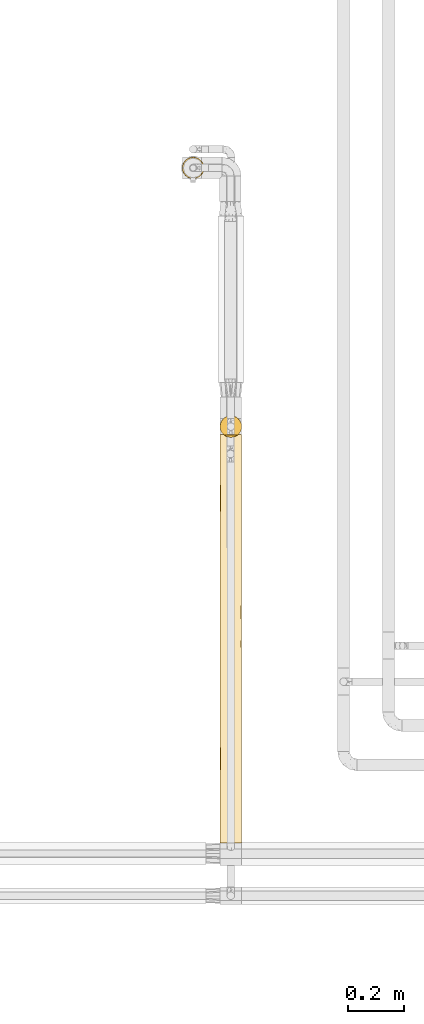
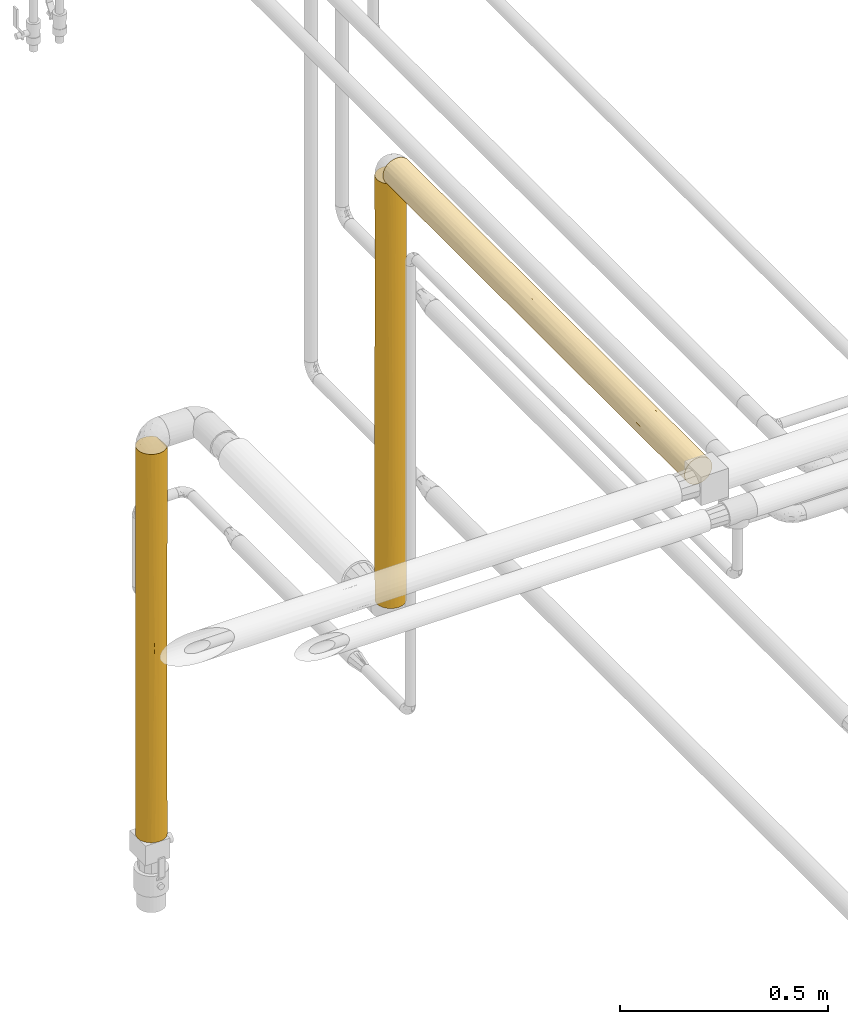
# One storey, part 26 of 827: 3 coverings.
"""IFC2X3 building model written with IfcOpenShell, lengths in millimetres."""

from ifc_helpers import new_model, entity, si_unit, converted_unit, derived_unit, direction, frame, origin, place, context, subcontext, project, spatial, faceted_brep, element, save


model = new_model("IFC2X3")

# Units and contexts
model_context = context("Model", 3, precision=0.01, world=origin(), true_north=direction((6.12303176911189e-17, 1.0)))
body_context = subcontext(model_context, "Body", "Model", "MODEL_VIEW")
ifc_project = project(units=[si_unit("LENGTHUNIT", "METRE", prefix="MILLI"), si_unit("AREAUNIT", "SQUARE_METRE"), si_unit("VOLUMEUNIT", "CUBIC_METRE"), converted_unit("PLANEANGLEUNIT", "DEGREE", entity("IfcRatioMeasure", 0.0174532925199433), si_unit("PLANEANGLEUNIT", "RADIAN"), dimensions=[0, 0, 0, 0, 0, 0, 0]), si_unit("MASSUNIT", "GRAM", prefix="KILO"), derived_unit("MASSDENSITYUNIT", [(si_unit("MASSUNIT", "GRAM", prefix="KILO"), 1), (si_unit("LENGTHUNIT", "METRE"), -3)]), derived_unit("MOMENTOFINERTIAUNIT", [(si_unit("LENGTHUNIT", "METRE"), 4)]), si_unit("TIMEUNIT", "SECOND"), si_unit("FREQUENCYUNIT", "HERTZ"), si_unit("THERMODYNAMICTEMPERATUREUNIT", "DEGREE_CELSIUS"), derived_unit("THERMALTRANSMITTANCEUNIT", [(si_unit("MASSUNIT", "GRAM", prefix="KILO"), 1), (si_unit("THERMODYNAMICTEMPERATUREUNIT", "KELVIN"), -1), (si_unit("TIMEUNIT", "SECOND"), -3)]), derived_unit("VOLUMETRICFLOWRATEUNIT", [(si_unit("LENGTHUNIT", "METRE"), 3), (si_unit("TIMEUNIT", "SECOND"), -1)]), derived_unit("MASSFLOWRATEUNIT", [(si_unit("MASSUNIT", "GRAM", prefix="KILO"), 1), (si_unit("TIMEUNIT", "SECOND"), -1)]), derived_unit("ROTATIONALFREQUENCYUNIT", [(si_unit("TIMEUNIT", "SECOND"), -1)]), si_unit("ELECTRICCURRENTUNIT", "AMPERE"), si_unit("ELECTRICVOLTAGEUNIT", "VOLT"), si_unit("POWERUNIT", "WATT"), si_unit("FORCEUNIT", "NEWTON", prefix="KILO"), si_unit("ILLUMINANCEUNIT", "LUX"), si_unit("LUMINOUSFLUXUNIT", "LUMEN"), si_unit("LUMINOUSINTENSITYUNIT", "CANDELA"), derived_unit("USERDEFINED", [(si_unit("MASSUNIT", "GRAM", prefix="KILO"), -1), (si_unit("LENGTHUNIT", "METRE"), -2), (si_unit("TIMEUNIT", "SECOND"), 3), (si_unit("LUMINOUSFLUXUNIT", "LUMEN"), 1)]), derived_unit("LINEARVELOCITYUNIT", [(si_unit("LENGTHUNIT", "METRE"), 1), (si_unit("TIMEUNIT", "SECOND"), -1)]), si_unit("PRESSUREUNIT", "PASCAL"), derived_unit("USERDEFINED", [(si_unit("LENGTHUNIT", "METRE"), -2), (si_unit("MASSUNIT", "GRAM", prefix="KILO"), 1), (si_unit("TIMEUNIT", "SECOND"), -2)]), derived_unit("LINEARFORCEUNIT", [(si_unit("MASSUNIT", "GRAM", prefix="KILO"), 1), (si_unit("LENGTHUNIT", "METRE"), 1), (si_unit("TIMEUNIT", "SECOND"), -2), (si_unit("LENGTHUNIT", "METRE"), -1)]), derived_unit("PLANARFORCEUNIT", [(si_unit("MASSUNIT", "GRAM", prefix="KILO"), 1), (si_unit("LENGTHUNIT", "METRE"), 1), (si_unit("TIMEUNIT", "SECOND"), -2), (si_unit("LENGTHUNIT", "METRE"), -2)])], contexts=[model_context])

# Site, building, storey
site_placement = place(None, origin())
site = spatial("IfcSite", under=ifc_project, at=site_placement, CompositionType="ELEMENT")
building_placement = place(site_placement, origin())
building = spatial("IfcBuilding", under=site, at=building_placement, CompositionType="ELEMENT")
storey_placement = place(building_placement, frame((0.0, 0.0, 28200.0)))
storey = spatial("IfcBuildingStorey", under=building, at=storey_placement, Name="08", CompositionType="ELEMENT", Elevation=28200.0)

# Coverings
covering_1_placement = place(storey_placement, frame((15160.93, 11220.3, 1573.25)))
element("IfcCovering", 1, at=covering_1_placement, inside=storey, Name=":ADSK_", ObjectType=":ADSK_", PredefinedType="INSULATION", context=body_context, shape_type="Brep", body=[
    faceted_brep([(74.9, 23.99, 1247.8), (77.51, 31.8, 1247.8), (78.4, 40.0, 1247.8), (77.09, 49.94, 1247.8), (73.25, 59.2, 1247.8), (67.15, 67.16, 1247.8), (59.2, 73.26, 1247.8), (49.93, 77.09, 1247.8), (40.0, 78.4, 1247.8), (30.06, 77.09, 1247.8), (20.8, 73.26, 1247.8), (12.84, 67.16, 1247.8), (6.74, 59.2, 1247.8), (2.9, 49.94, 1247.8), (1.6, 40.0, 1247.8), (2.48, 31.8, 1247.8), (5.09, 23.99, 1247.8), (9.31, 16.92, 1247.8), (14.94, 10.9, 1247.8), (65.05, 10.9, 1247.8), (70.68, 16.92, 1247.8), (77.09, 30.06, 1.6), (73.25, 20.8, 1.6), (67.15, 12.84, 1.6), (59.2, 6.74, 1.6), (49.93, 2.9, 1.6), (40.0, 1.6, 1.6), (30.06, 2.9, 1.6), (20.8, 6.74, 1.6), (12.84, 12.84, 1.6), (6.74, 20.8, 1.6), (2.9, 30.06, 1.6), (1.6, 40.0, 1.6), (2.48, 48.2, 1.6), (5.09, 56.01, 1.6), (9.31, 63.08, 1.6), (14.94, 69.1, 1.6), (65.05, 69.1, 1.6), (70.68, 63.08, 1.6), (74.9, 56.01, 1.6), (77.51, 48.2, 1.6), (78.4, 40.0, 1.6), (1.6, 40.0, 1031.43), (3.58, 27.82, 972.47), (8.22, 18.43, 534.65), (11.62, 14.13, 710.8), (7.01, 20.34, 789.72), (7.01, 20.34, 1034.19), (32.71, 2.29, 239.13), (25.3, 4.52, 351.94), (31.81, 2.48, 598.5), (40.0, 1.6, 373.01), (40.0, 1.6, 589.38), (40.0, 1.6, 805.76), (4.52, 25.3, 398.65), (4.52, 25.3, 173.7), (9.53, 16.62, 279.39), (2.18, 33.3, 229.26), (31.85, 2.47, 913.94), (26.63, 4.0, 1240.9), (20.48, 6.93, 1243.83), (23.33, 5.4, 906.25), (11.96, 13.76, 972.47), (16.85, 9.36, 848.05), (17.27, 9.05, 621.73), (24.29, 4.96, 668.96), (3.17, 29.13, 675.0), (33.21, 2.21, 1239.11), (40.0, 1.6, 1022.13), (40.0, 1.6, 1238.5), (17.51, 8.87, 1058.4), (16.62, 9.53, 253.79), (1.6, 40.0, 382.31), (2.32, 32.59, 455.14), (1.6, 40.0, 815.06), (1.6, 40.0, 598.68), (1.6, 40.0, 217.97), (1.6, 40.0, 650.71), (1.6, 40.0, 434.34), (1.6, 40.0, 867.09), (70.46, 16.62, 279.39), (63.37, 9.53, 253.79), (71.77, 18.43, 534.65), (68.37, 14.13, 710.8), (62.72, 9.05, 621.73), (47.28, 2.29, 239.13), (54.69, 4.52, 351.94), (59.51, 6.93, 1243.83), (62.29, 8.74, 1035.74), (56.66, 5.4, 906.25), (48.14, 2.47, 913.94), (48.18, 2.48, 598.5), (75.47, 25.3, 173.7), (62.38, 8.8, 828.57), (68.03, 13.76, 972.47), (53.36, 4.0, 1240.9), (77.81, 33.3, 229.26), (78.4, 40.0, 217.97), (78.4, 40.0, 382.31), (76.82, 29.13, 675.0), (77.67, 32.59, 455.14), (78.4, 40.0, 598.68), (75.47, 25.3, 398.65), (46.78, 2.21, 1239.11), (76.41, 27.82, 972.47), (78.4, 40.0, 1031.43), (72.98, 20.34, 1034.19), (72.98, 20.34, 789.72), (55.84, 5.02, 582.58), (78.4, 40.0, 815.06), (78.4, 40.0, 650.71), (78.4, 40.0, 434.34), (78.4, 40.0, 867.09), (76.82, 50.87, 574.4), (76.41, 52.17, 276.92), (72.98, 59.66, 459.68), (62.72, 70.95, 627.67), (56.36, 74.73, 369.43), (51.95, 76.49, 536.5), (46.78, 77.79, 10.29), (40.0, 78.4, 227.27), (50.19, 77.02, 266.42), (75.47, 54.7, 850.75), (75.47, 54.7, 1075.7), (77.81, 46.69, 1020.14), (77.67, 47.41, 794.26), (72.98, 59.66, 215.21), (68.71, 65.5, 576.7), (68.71, 65.5, 337.44), (62.54, 71.08, 307.88), (53.36, 76.0, 8.5), (59.51, 73.07, 5.57), (70.46, 63.38, 970.01), (47.09, 77.74, 783.96), (40.0, 78.4, 629.35), (40.0, 78.4, 660.02), (40.0, 78.4, 876.39), (40.0, 78.4, 938.58), (63.37, 70.47, 995.61), (40.0, 78.4, 443.64), (54.69, 75.48, 901.9), (47.66, 77.63, 1020.45), (71.93, 61.33, 750.72), (66.93, 67.37, 796.38), (40.0, 78.4, 10.9), (11.96, 66.24, 276.93), (16.85, 70.64, 401.35), (17.51, 71.13, 191.0), (9.53, 63.38, 970.01), (7.01, 59.66, 215.21), (16.62, 70.47, 995.61), (33.21, 77.79, 10.29), (26.63, 76.0, 8.5), (31.85, 77.52, 335.45), (20.48, 73.07, 5.57), (17.27, 70.95, 627.67), (24.29, 75.04, 580.43), (3.58, 52.17, 276.92), (32.71, 77.7, 1010.27), (2.18, 46.69, 1020.14), (8.22, 61.57, 714.75), (11.62, 65.87, 538.6), (7.01, 59.66, 459.68), (23.33, 74.59, 343.15), (25.3, 75.48, 897.46), (4.52, 54.7, 1075.7), (3.17, 50.87, 574.4), (4.52, 54.7, 850.75), (31.81, 77.52, 650.9), (2.32, 47.41, 794.26)], [[[0, 1, 2, 3, 4, 5, 6, 7, 8, 9, 10, 11, 12, 13, 14, 15, 16, 17, 18, 19, 20]], [[21, 22, 23, 24, 25, 26, 27, 28, 29, 30, 31, 32, 33, 34, 35, 36, 37, 38, 39, 40, 41]], [[15, 42, 43]], [[44, 45, 46]], [[47, 43, 46]], [[27, 48, 49]], [[50, 51, 52, 53]], [[54, 55, 56]], [[56, 44, 54]], [[57, 32, 31]], [[50, 53, 58]], [[55, 31, 30]], [[59, 60, 61]], [[17, 62, 18]], [[17, 16, 47]], [[63, 64, 65]], [[17, 47, 62]], [[46, 43, 66]], [[49, 50, 65]], [[67, 58, 68]], [[68, 69, 67]], [[30, 29, 56]], [[51, 48, 26]], [[27, 49, 28]], [[63, 70, 62]], [[67, 59, 58]], [[70, 60, 18]], [[56, 29, 71]], [[72, 57, 73]], [[71, 64, 56]], [[31, 55, 57]], [[43, 16, 15]], [[49, 65, 64]], [[66, 54, 44]], [[58, 59, 61]], [[53, 68, 58]], [[63, 65, 61]], [[65, 58, 61]], [[50, 49, 48]], [[29, 28, 71]], [[44, 46, 66]], [[43, 47, 16]], [[62, 47, 46]], [[43, 74, 66]], [[66, 75, 73]], [[28, 49, 71]], [[64, 71, 49]], [[56, 64, 44]], [[45, 44, 64]], [[63, 45, 64]], [[62, 46, 45]], [[56, 55, 30]], [[54, 73, 57]], [[54, 57, 55]], [[57, 72, 76, 32]], [[54, 66, 73]], [[26, 48, 27]], [[66, 74, 77, 75]], [[73, 75, 78, 72]], [[50, 48, 51]], [[70, 61, 60]], [[45, 63, 62]], [[62, 70, 18]], [[61, 70, 63]], [[42, 15, 14]], [[43, 42, 79, 74]], [[58, 65, 50]], [[23, 80, 81]], [[82, 83, 84]], [[85, 26, 25]], [[85, 25, 86]], [[19, 87, 88]], [[87, 89, 88]], [[24, 86, 25]], [[89, 90, 91]], [[92, 80, 22]], [[90, 68, 53]], [[24, 23, 81]], [[93, 83, 94]], [[95, 89, 87]], [[21, 92, 22]], [[96, 41, 97, 98]], [[99, 100, 101]], [[102, 82, 80]], [[51, 85, 91]], [[102, 92, 96]], [[68, 90, 103]], [[19, 94, 20]], [[22, 80, 23]], [[0, 104, 1]], [[105, 1, 104]], [[20, 106, 0]], [[0, 106, 104]], [[95, 103, 90]], [[107, 106, 94]], [[108, 89, 91]], [[99, 104, 107]], [[107, 82, 99]], [[105, 2, 1]], [[103, 69, 68]], [[91, 90, 53]], [[90, 89, 95]], [[91, 53, 52, 51]], [[91, 86, 108]], [[102, 99, 82]], [[81, 84, 86]], [[94, 106, 20]], [[104, 106, 107]], [[100, 102, 96]], [[109, 104, 99]], [[84, 81, 80]], [[86, 24, 81]], [[83, 82, 107]], [[84, 80, 82]], [[107, 94, 83]], [[93, 94, 88]], [[96, 92, 21]], [[80, 92, 102]], [[41, 96, 21]], [[96, 98, 100]], [[99, 101, 110, 109]], [[99, 102, 100]], [[100, 98, 111, 101]], [[91, 85, 86]], [[26, 85, 51]], [[93, 88, 89]], [[19, 88, 94]], [[108, 93, 89]], [[83, 93, 84]], [[104, 109, 112, 105]], [[86, 84, 108]], [[108, 84, 93]], [[113, 114, 115]], [[116, 117, 118]], [[119, 120, 121]], [[122, 123, 124]], [[113, 125, 110]], [[3, 123, 4]], [[97, 40, 114]], [[126, 39, 38]], [[39, 126, 114]], [[127, 115, 128]], [[129, 128, 37]], [[124, 2, 105, 112]], [[128, 115, 126]], [[117, 121, 118]], [[130, 117, 131]], [[123, 132, 4]], [[133, 134, 135, 136, 137]], [[6, 5, 138]], [[118, 121, 139]], [[121, 130, 119]], [[39, 114, 40]], [[140, 116, 118]], [[129, 117, 116]], [[6, 140, 7]], [[118, 139, 134]], [[141, 140, 133]], [[130, 121, 117]], [[131, 129, 37]], [[127, 128, 129]], [[4, 132, 5]], [[5, 132, 138]], [[125, 122, 124]], [[115, 142, 113]], [[97, 41, 40]], [[142, 115, 127]], [[138, 116, 140]], [[38, 37, 128]], [[114, 126, 115]], [[133, 118, 134]], [[7, 141, 8]], [[111, 114, 113]], [[138, 132, 143]], [[140, 6, 138]], [[38, 128, 126]], [[127, 129, 116]], [[116, 143, 127]], [[127, 143, 142]], [[138, 143, 116]], [[142, 143, 132]], [[132, 122, 142]], [[142, 122, 113]], [[141, 133, 137]], [[118, 133, 140]], [[8, 141, 137]], [[140, 141, 7]], [[124, 123, 3]], [[132, 123, 122]], [[2, 124, 3]], [[124, 112, 125]], [[113, 110, 101, 111]], [[113, 122, 125]], [[125, 112, 109, 110]], [[120, 119, 144]], [[120, 139, 121]], [[131, 117, 129]], [[114, 111, 98, 97]], [[145, 146, 147]], [[12, 11, 148]], [[149, 35, 34]], [[148, 11, 150]], [[151, 152, 153]], [[36, 147, 154]], [[151, 153, 120]], [[146, 155, 156]], [[33, 76, 157]], [[35, 149, 145]], [[158, 8, 137, 136]], [[14, 13, 159]], [[155, 148, 150]], [[160, 161, 162]], [[152, 154, 163]], [[9, 158, 164]], [[13, 12, 165]], [[162, 157, 166]], [[13, 165, 159]], [[167, 148, 160]], [[157, 34, 33]], [[148, 167, 165]], [[164, 168, 156]], [[35, 145, 36]], [[149, 157, 162]], [[79, 159, 169]], [[120, 144, 151]], [[164, 10, 9]], [[168, 136, 135, 134, 139]], [[168, 139, 153]], [[164, 156, 155]], [[166, 167, 160]], [[153, 152, 163]], [[139, 120, 153]], [[146, 156, 163]], [[156, 153, 163]], [[168, 164, 158]], [[11, 10, 150]], [[160, 162, 166]], [[157, 149, 34]], [[145, 149, 162]], [[157, 78, 166]], [[166, 77, 169]], [[10, 164, 150]], [[155, 150, 164]], [[148, 155, 160]], [[161, 160, 155]], [[146, 161, 155]], [[145, 162, 161]], [[148, 165, 12]], [[167, 169, 159]], [[167, 159, 165]], [[159, 79, 42, 14]], [[167, 166, 169]], [[8, 158, 9]], [[166, 78, 75, 77]], [[169, 77, 74, 79]], [[168, 158, 136]], [[147, 163, 154]], [[161, 146, 145]], [[145, 147, 36]], [[163, 147, 146]], [[76, 33, 32]], [[157, 76, 72, 78]], [[153, 156, 168]], [[60, 59, 67, 69, 103, 95, 87, 19, 18]], [[154, 152, 151, 144, 119, 130, 131, 37, 36]]]),
])
covering_2_placement = place(storey_placement, frame((15160.93, 9780.8, 2810.09)))
element("IfcCovering", 2, at=covering_2_placement, inside=storey, Name=":ADSK_", ObjectType=":ADSK_", PredefinedType="INSULATION", context=body_context, shape_type="Brep", body=[
    faceted_brep([(40.0, 1450.41, 78.46), (49.93, 1450.41, 77.15), (59.2, 1450.41, 73.32), (67.15, 1450.41, 67.21), (73.25, 1450.41, 59.26), (77.09, 1450.41, 50.0), (78.4, 1450.41, 40.06), (77.51, 1450.41, 31.86), (74.9, 1450.41, 24.05), (70.68, 1450.41, 16.97), (65.05, 1450.41, 10.96), (14.94, 1450.41, 10.96), (9.31, 1450.41, 16.97), (5.09, 1450.41, 24.05), (2.48, 1450.41, 31.86), (1.6, 1450.41, 40.06), (2.9, 1450.41, 50.0), (6.74, 1450.41, 59.26), (12.84, 1450.41, 67.21), (20.8, 1450.41, 73.32), (30.06, 1450.41, 77.15), (40.0, 0.0, 78.4), (30.06, 0.0, 77.09), (20.8, 0.0, 73.25), (12.84, 0.0, 67.15), (6.74, 0.0, 59.2), (2.9, 0.0, 49.93), (1.6, 0.0, 40.0), (2.9, 0.0, 30.06), (6.74, 0.0, 20.8), (12.84, 0.0, 12.84), (20.8, 0.0, 6.74), (30.06, 0.0, 2.9), (40.0, 0.0, 1.6), (49.93, 0.0, 2.9), (59.2, 0.0, 6.74), (67.15, 0.0, 12.84), (73.25, 0.0, 20.8), (77.09, 0.0, 30.06), (78.4, 0.0, 40.0), (77.09, 0.0, 49.93), (73.25, 0.0, 59.2), (67.15, 0.0, 67.15), (59.2, 0.0, 73.25), (49.93, 0.0, 77.09), (76.41, 1164.77, 27.87), (78.4, 1234.03, 40.05), (78.4, 1157.95, 40.05), (78.4, 1017.65, 40.04), (48.24, 1116.55, 2.54), (53.36, 1443.51, 4.06), (56.68, 1067.01, 5.46), (63.21, 1045.15, 9.45), (68.03, 1164.76, 13.8), (67.73, 907.86, 13.48), (46.71, 431.71, 2.21), (49.98, 226.65, 2.93), (40.0, 287.81, 1.61), (40.0, 1008.36, 1.64), (50.46, 763.94, 3.08), (40.0, 575.61, 1.62), (40.0, 791.98, 1.63), (75.47, 435.95, 25.32), (75.47, 193.91, 25.31), (70.46, 290.17, 16.63), (78.4, 292.46, 40.01), (77.54, 314.93, 31.97), (77.57, 548.0, 32.09), (70.69, 629.12, 16.95), (72.98, 966.82, 20.38), (72.98, 1233.34, 20.39), (40.0, 1224.74, 1.65), (57.11, 845.95, 5.66), (56.98, 618.11, 5.58), (46.78, 1441.71, 2.27), (40.0, 1441.11, 1.66), (62.48, 1257.94, 8.92), (56.86, 199.6, 5.5), (59.51, 1446.44, 6.99), (63.37, 253.55, 9.54), (77.14, 835.19, 30.29), (54.69, 402.05, 4.54), (63.08, 494.18, 9.33), (75.6, 660.18, 25.65), (78.4, 801.29, 40.03), (78.4, 649.13, 40.02), (78.4, 584.91, 40.02), (78.4, 432.75, 40.02), (62.77, 734.81, 9.11), (78.4, 216.37, 40.01), (78.4, 865.49, 40.03), (9.53, 290.17, 16.63), (16.62, 253.55, 9.54), (16.78, 1045.15, 9.45), (17.22, 734.81, 9.11), (12.26, 907.86, 13.48), (33.28, 431.71, 2.21), (30.01, 226.65, 2.93), (25.3, 402.05, 4.54), (17.51, 1257.94, 8.92), (20.48, 1446.44, 6.99), (23.31, 1067.01, 5.46), (23.14, 199.6, 5.5), (26.63, 1443.51, 4.06), (4.52, 193.91, 25.31), (31.75, 1116.55, 2.54), (33.21, 1441.71, 2.27), (11.96, 1164.76, 13.8), (3.58, 1164.77, 27.87), (1.6, 1234.04, 40.05), (29.53, 763.94, 3.08), (17.41, 493.39, 8.96), (9.3, 629.12, 16.95), (2.45, 314.93, 31.97), (4.52, 435.95, 25.32), (2.42, 548.0, 32.09), (7.01, 1233.34, 20.39), (7.01, 966.82, 20.38), (2.85, 835.19, 30.29), (1.6, 1017.66, 40.04), (22.82, 847.26, 5.69), (23.38, 627.69, 5.4), (1.6, 292.46, 40.01), (4.39, 660.18, 25.65), (1.6, 801.29, 40.03), (1.6, 584.92, 40.02), (9.53, 259.19, 63.38), (16.62, 324.27, 70.47), (4.52, 1045.09, 54.74), (2.29, 1125.85, 47.34), (2.42, 828.76, 47.96), (3.38, 211.68, 51.58), (2.91, 597.39, 49.98), (2.27, 385.18, 47.19), (4.52, 406.68, 54.71), (40.0, 216.37, 78.41), (7.27, 539.63, 60.11), (5.04, 752.83, 55.92), (28.13, 772.09, 76.55), (32.71, 957.77, 77.74), (25.3, 1014.46, 75.52), (9.53, 1196.86, 63.43), (16.62, 1160.24, 70.51), (17.89, 567.01, 71.42), (11.76, 492.97, 66.04), (25.3, 245.05, 75.48), (32.71, 324.56, 77.71), (25.3, 529.72, 75.5), (8.28, 961.8, 61.69), (17.11, 834.81, 70.87), (33.12, 561.65, 77.8), (23.37, 1236.22, 74.66), (30.78, 1201.25, 77.33), (3.89, 1255.76, 53.13), (9.53, 726.75, 63.4), (40.0, 292.46, 78.41), (40.0, 432.75, 78.42), (40.0, 649.12, 78.42), (40.0, 801.28, 78.43), (40.0, 865.49, 78.43), (40.0, 584.91, 78.42), (40.0, 1017.66, 78.44), (40.0, 1157.95, 78.45), (40.0, 1234.03, 78.45), (63.37, 259.19, 70.47), (70.46, 324.27, 63.39), (54.69, 1045.09, 75.52), (47.28, 1125.85, 77.75), (47.92, 828.76, 77.61), (51.57, 211.68, 76.62), (49.96, 597.39, 77.11), (47.17, 385.18, 77.74), (54.69, 406.68, 75.49), (60.09, 539.63, 72.74), (55.88, 752.83, 74.99), (76.52, 772.09, 51.9), (77.7, 957.78, 47.32), (75.47, 1014.46, 54.74), (63.37, 1196.86, 70.51), (70.46, 1160.24, 63.42), (71.4, 567.01, 62.12), (66.02, 492.97, 68.26), (75.47, 245.05, 54.7), (77.7, 324.56, 47.29), (75.47, 529.72, 54.71), (61.64, 961.8, 71.75), (70.83, 834.81, 62.92), (77.77, 561.65, 46.9), (74.61, 1236.22, 56.68), (77.27, 1201.25, 49.27), (53.07, 1255.75, 76.16), (63.37, 726.75, 70.49)], [[[0, 1, 2, 3, 4, 5, 6, 7, 8, 9, 10, 11, 12, 13, 14, 15, 16, 17, 18, 19, 20]], [[21, 22, 23, 24, 25, 26, 27, 28, 29, 30, 31, 32, 33, 34, 35, 36, 37, 38, 39, 40, 41, 42, 43, 44]], [[45, 46, 47, 48]], [[49, 50, 51]], [[52, 53, 54]], [[55, 56, 57]], [[58, 59, 60, 61]], [[62, 63, 64]], [[37, 63, 38]], [[65, 66, 67]], [[64, 68, 62]], [[54, 53, 69]], [[38, 63, 66]], [[69, 53, 70]], [[53, 9, 70]], [[58, 71, 49]], [[45, 70, 8]], [[37, 36, 64]], [[59, 72, 73]], [[74, 50, 49]], [[71, 75, 74]], [[52, 76, 53]], [[57, 56, 33]], [[56, 77, 34]], [[49, 59, 58]], [[9, 53, 10]], [[76, 50, 78]], [[64, 36, 79]], [[69, 45, 80]], [[79, 81, 82]], [[83, 80, 67]], [[45, 8, 7]], [[76, 78, 10]], [[45, 7, 46]], [[80, 45, 48]], [[74, 49, 71]], [[49, 51, 59]], [[72, 59, 51]], [[59, 73, 55]], [[36, 35, 79]], [[38, 66, 39]], [[79, 82, 64]], [[67, 84, 85, 86, 87, 65]], [[60, 55, 57]], [[54, 68, 88]], [[83, 69, 80]], [[7, 6, 46]], [[77, 79, 35]], [[81, 73, 82]], [[59, 55, 60]], [[56, 55, 81]], [[77, 56, 81]], [[56, 34, 33]], [[79, 77, 81]], [[34, 77, 35]], [[64, 63, 37]], [[66, 63, 62]], [[66, 62, 67]], [[66, 65, 89, 39]], [[83, 67, 62]], [[67, 80, 84]], [[62, 68, 83]], [[69, 83, 68]], [[68, 54, 69]], [[88, 72, 52]], [[88, 52, 54]], [[51, 50, 76]], [[53, 76, 10]], [[51, 76, 52]], [[8, 70, 9]], [[69, 70, 45]], [[52, 72, 51]], [[73, 72, 88]], [[73, 88, 82]], [[73, 81, 55]], [[88, 68, 82]], [[64, 82, 68]], [[80, 48, 90, 84]], [[30, 91, 92]], [[93, 94, 95]], [[96, 60, 57]], [[97, 98, 96]], [[99, 11, 100]], [[99, 101, 93]], [[97, 102, 98]], [[103, 101, 99]], [[104, 91, 29]], [[71, 105, 106]], [[31, 30, 92]], [[11, 107, 12]], [[105, 71, 58]], [[108, 109, 14]], [[110, 101, 105]], [[94, 111, 112]], [[113, 114, 104]], [[111, 98, 92]], [[114, 113, 115]], [[107, 116, 12]], [[107, 95, 117]], [[116, 13, 12]], [[13, 108, 14]], [[28, 104, 29]], [[118, 119, 108]], [[29, 91, 30]], [[103, 106, 105]], [[117, 108, 116]], [[120, 110, 121]], [[122, 113, 27]], [[118, 108, 117]], [[14, 109, 15]], [[106, 75, 71]], [[110, 58, 61, 60]], [[105, 101, 103]], [[96, 110, 60]], [[110, 96, 121]], [[112, 91, 114]], [[122, 115, 113]], [[94, 121, 111]], [[117, 112, 123]], [[32, 97, 33]], [[115, 124, 118]], [[123, 114, 115]], [[95, 112, 117]], [[91, 112, 111]], [[119, 109, 108]], [[102, 92, 98]], [[57, 33, 97]], [[96, 98, 121]], [[57, 97, 96]], [[102, 32, 31]], [[32, 102, 97]], [[92, 102, 31]], [[28, 27, 113]], [[91, 104, 114]], [[28, 113, 104]], [[115, 122, 125, 124]], [[123, 115, 118]], [[117, 123, 118]], [[112, 114, 123]], [[93, 95, 107]], [[112, 95, 94]], [[107, 11, 99]], [[93, 101, 120]], [[99, 100, 103]], [[107, 99, 93]], [[117, 116, 107]], [[13, 116, 108]], [[58, 110, 105]], [[120, 121, 94]], [[98, 111, 121]], [[111, 92, 91]], [[93, 120, 94]], [[110, 120, 101]], [[124, 119, 118]], [[126, 24, 127]], [[128, 129, 130]], [[16, 109, 129]], [[25, 24, 126]], [[25, 126, 131]], [[132, 133, 134]], [[22, 21, 135]], [[132, 136, 137]], [[137, 128, 130]], [[138, 139, 140]], [[141, 142, 18]], [[127, 143, 144]], [[145, 146, 147]], [[142, 148, 149]], [[150, 138, 147]], [[151, 140, 152]], [[153, 16, 129]], [[23, 22, 145]], [[23, 127, 24]], [[140, 142, 149]], [[142, 140, 151]], [[139, 152, 140]], [[19, 18, 142]], [[119, 129, 109]], [[131, 134, 133]], [[145, 127, 23]], [[147, 146, 150]], [[136, 126, 144]], [[18, 17, 141]], [[20, 152, 0]], [[141, 148, 142]], [[144, 126, 127]], [[26, 131, 27]], [[131, 126, 134]], [[153, 141, 17]], [[148, 141, 128]], [[154, 144, 143]], [[149, 143, 138]], [[135, 146, 22]], [[127, 145, 147]], [[146, 135, 155, 156]], [[146, 156, 150]], [[22, 146, 145]], [[138, 157, 158, 159]], [[159, 139, 138]], [[150, 157, 138]], [[149, 138, 140]], [[150, 156, 160, 157]], [[16, 15, 109]], [[130, 129, 119]], [[129, 128, 153]], [[130, 119, 124, 125]], [[132, 134, 136]], [[141, 153, 128]], [[17, 16, 153]], [[139, 159, 161, 162]], [[152, 162, 163, 0]], [[162, 152, 139]], [[151, 20, 19]], [[20, 151, 152]], [[142, 151, 19]], [[127, 147, 143]], [[136, 144, 154]], [[138, 143, 147]], [[154, 143, 149]], [[137, 136, 154]], [[126, 136, 134]], [[137, 154, 148]], [[137, 130, 132]], [[130, 125, 132]], [[133, 125, 122]], [[125, 133, 132]], [[122, 27, 131]], [[122, 131, 133]], [[25, 131, 26]], [[137, 148, 128]], [[149, 148, 154]], [[164, 42, 165]], [[166, 167, 168]], [[1, 163, 167]], [[43, 42, 164]], [[43, 164, 169]], [[170, 171, 172]], [[40, 39, 89]], [[170, 173, 174]], [[174, 166, 168]], [[175, 176, 177]], [[178, 179, 3]], [[165, 180, 181]], [[182, 183, 184]], [[179, 185, 186]], [[187, 175, 184]], [[188, 177, 189]], [[190, 1, 167]], [[41, 40, 182]], [[41, 165, 42]], [[177, 179, 186]], [[179, 177, 188]], [[176, 189, 177]], [[4, 3, 179]], [[167, 163, 162, 161]], [[169, 172, 171]], [[182, 165, 41]], [[184, 183, 187]], [[173, 164, 181]], [[3, 2, 178]], [[5, 189, 6]], [[178, 185, 179]], [[181, 164, 165]], [[44, 169, 21]], [[169, 164, 172]], [[190, 178, 2]], [[185, 178, 166]], [[191, 181, 180]], [[186, 180, 175]], [[89, 183, 40]], [[165, 182, 184]], [[183, 89, 65, 87]], [[183, 87, 187]], [[40, 183, 182]], [[175, 85, 84, 90]], [[90, 176, 175]], [[187, 85, 175]], [[186, 175, 177]], [[187, 87, 86, 85]], [[1, 0, 163]], [[168, 167, 161]], [[167, 166, 190]], [[168, 161, 159, 158, 157, 160]], [[170, 172, 173]], [[178, 190, 166]], [[2, 1, 190]], [[176, 90, 48, 47]], [[189, 47, 46, 6]], [[47, 189, 176]], [[188, 5, 4]], [[5, 188, 189]], [[179, 188, 4]], [[165, 184, 180]], [[173, 181, 191]], [[175, 180, 184]], [[191, 180, 186]], [[174, 173, 191]], [[164, 173, 172]], [[174, 191, 185]], [[174, 168, 170]], [[168, 160, 170]], [[171, 160, 156, 155]], [[160, 171, 170]], [[169, 155, 135, 21]], [[155, 169, 171]], [[43, 169, 44]], [[174, 185, 166]], [[186, 185, 191]], [[78, 50, 74, 75, 106, 103, 100, 11, 10]]]),
])
covering_3_placement = place(storey_placement, frame((15026.98, 12139.42, 376.5)))
element("IfcCovering", 3, at=covering_3_placement, inside=storey, Name=":ADSK_", ObjectType=":ADSK_", PredefinedType="INSULATION", context=body_context, shape_type="Brep", body=[
    faceted_brep([(6.74, 20.8, 0.0), (2.9, 30.06, 0.0), (1.6, 40.0, 0.0), (2.9, 49.93, 0.0), (6.74, 59.2, 0.0), (12.84, 67.15, 0.0), (20.8, 73.25, 0.0), (30.06, 77.09, 0.0), (40.0, 78.4, 0.0), (49.93, 77.09, 0.0), (59.2, 73.25, 0.0), (67.15, 67.15, 0.0), (73.25, 59.2, 0.0), (77.09, 49.93, 0.0), (78.4, 40.0, 0.0), (77.09, 30.06, 0.0), (73.25, 20.8, 0.0), (67.15, 12.84, 0.0), (59.2, 6.74, 0.0), (49.93, 2.9, 0.0), (40.0, 1.6, 0.0), (30.06, 2.9, 0.0), (20.8, 6.74, 0.0), (12.84, 12.84, 0.0), (2.9, 30.06, 1140.15), (6.74, 20.8, 1140.15), (12.84, 12.85, 1140.15), (20.8, 6.75, 1140.15), (30.06, 2.91, 1140.15), (40.0, 1.6, 1140.15), (48.2, 2.49, 1140.15), (56.01, 5.1, 1140.15), (63.08, 9.32, 1140.15), (69.1, 14.95, 1140.15), (69.1, 65.06, 1140.15), (63.08, 70.69, 1140.15), (56.01, 74.91, 1140.15), (48.2, 77.52, 1140.15), (40.0, 78.4, 1140.15), (30.06, 77.1, 1140.15), (20.8, 73.26, 1140.15), (12.84, 67.16, 1140.15), (6.74, 59.2, 1140.15), (2.9, 49.94, 1140.15), (1.6, 40.0, 1140.15), (4.52, 54.7, 867.11), (9.53, 63.38, 888.36), (3.49, 51.91, 570.07), (2.26, 47.13, 324.56), (1.6, 40.0, 432.75), (1.6, 40.0, 923.77), (2.26, 47.14, 815.59), (1.6, 40.0, 707.4), (16.62, 70.47, 799.9), (32.92, 77.74, 567.24), (25.3, 75.48, 472.34), (26.94, 76.11, 674.93), (25.3, 75.48, 877.52), (9.53, 63.38, 570.07), (1.6, 40.0, 216.37), (32.81, 77.72, 815.59), (16.62, 70.46, 302.8), (9.53, 63.37, 251.79), (4.52, 54.69, 273.04), (24.22, 75.01, 224.32), (31.72, 77.49, 328.0), (15.56, 69.63, 551.35), (40.0, 78.4, 707.4), (40.0, 78.4, 923.77), (1.6, 40.0, 353.69), (40.0, 78.4, 432.75), (40.0, 78.4, 353.7), (40.0, 78.4, 216.37), (59.66, 72.99, 933.08), (52.17, 76.42, 869.67), (48.63, 77.42, 570.07), (59.66, 72.98, 694.31), (54.69, 75.47, 350.56), (73.07, 59.52, 1136.18), (71.15, 62.44, 935.4), (65.89, 68.35, 639.18), (66.24, 68.03, 869.66), (63.37, 70.46, 265.06), (70.46, 63.37, 251.27), (47.05, 77.74, 324.56), (74.6, 56.65, 822.91), (76.0, 53.37, 1133.25), (76.14, 52.96, 585.48), (77.52, 48.15, 806.29), (77.75, 47.03, 324.56), (78.4, 40.0, 432.75), (78.4, 40.0, 216.37), (78.4, 40.0, 914.47), (78.4, 40.0, 698.1), (75.47, 54.69, 327.05), (77.79, 46.79, 1131.45), (70.97, 62.7, 567.02), (61.6, 71.75, 480.15), (78.4, 40.0, 1130.85), (66.24, 11.97, 869.66), (70.8, 17.07, 782.57), (77.79, 33.22, 1131.45), (75.47, 25.3, 327.05), (63.37, 9.53, 265.06), (70.46, 16.62, 251.27), (73.07, 20.49, 1136.18), (74.6, 23.35, 822.91), (76.0, 26.64, 1133.25), (77.52, 31.85, 806.29), (59.66, 7.02, 933.08), (76.14, 27.03, 585.48), (54.69, 4.52, 350.56), (59.66, 7.02, 694.31), (52.17, 3.58, 869.67), (48.63, 2.58, 570.07), (70.97, 17.3, 567.02), (40.0, 1.6, 216.37), (40.0, 1.6, 432.74), (47.05, 2.25, 324.56), (61.6, 8.25, 480.15), (40.0, 1.6, 707.4), (77.75, 32.96, 324.56), (65.89, 11.65, 639.18), (40.0, 1.6, 923.77), (2.5, 31.72, 328.0), (16.62, 9.53, 251.79), (25.3, 4.52, 273.04), (32.86, 2.27, 815.59), (32.86, 2.27, 324.56), (25.3, 4.52, 867.11), (2.27, 32.82, 815.59), (28.08, 3.49, 570.07), (2.25, 32.92, 567.24), (4.52, 25.3, 472.34), (3.88, 26.94, 674.93), (9.53, 16.62, 799.9), (10.37, 15.57, 551.35), (16.62, 9.53, 570.07), (4.98, 24.23, 224.32), (4.52, 25.31, 877.52), (16.62, 9.54, 888.36), (9.53, 16.62, 302.8)], [[[0, 1, 2, 3, 4, 5, 6, 7, 8, 9, 10, 11, 12, 13, 14, 15, 16, 17, 18, 19, 20, 21, 22, 23]], [[24, 25, 26, 27, 28, 29, 30, 31, 32, 33, 34, 35, 36, 37, 38, 39, 40, 41, 42, 43, 44]], [[45, 42, 46]], [[47, 48, 49]], [[50, 51, 52]], [[43, 45, 51]], [[41, 40, 53]], [[54, 55, 56]], [[57, 40, 39]], [[47, 45, 58]], [[47, 49, 52]], [[3, 2, 59]], [[50, 44, 43]], [[53, 40, 57]], [[46, 58, 45]], [[54, 56, 60]], [[61, 6, 5]], [[62, 4, 63]], [[64, 55, 65]], [[62, 5, 4]], [[63, 4, 3]], [[61, 55, 64]], [[54, 65, 55]], [[43, 42, 45]], [[66, 55, 61]], [[67, 60, 68]], [[7, 65, 8]], [[58, 66, 62]], [[53, 66, 58]], [[48, 59, 69, 49]], [[58, 63, 47]], [[41, 46, 42]], [[47, 52, 51]], [[43, 51, 50]], [[47, 51, 45]], [[68, 60, 39]], [[53, 57, 56]], [[58, 62, 63]], [[61, 5, 62]], [[41, 53, 46]], [[58, 46, 53]], [[39, 38, 68]], [[60, 67, 54]], [[39, 60, 57]], [[54, 67, 70, 71]], [[65, 54, 71]], [[65, 71, 72, 8]], [[64, 7, 6]], [[7, 64, 65]], [[61, 64, 6]], [[48, 47, 63]], [[59, 48, 3]], [[3, 48, 63]], [[56, 55, 66]], [[60, 56, 57]], [[66, 53, 56]], [[62, 66, 61]], [[73, 74, 36]], [[75, 76, 77]], [[77, 10, 9]], [[34, 78, 79]], [[80, 76, 81]], [[81, 35, 34]], [[73, 36, 35]], [[37, 74, 68]], [[36, 74, 37]], [[11, 10, 82]], [[82, 83, 11]], [[75, 84, 70]], [[73, 81, 76]], [[75, 67, 74]], [[85, 78, 86]], [[77, 82, 10]], [[87, 85, 88]], [[12, 11, 83]], [[89, 90, 91]], [[92, 93, 88]], [[90, 89, 87]], [[94, 13, 12]], [[84, 72, 71, 70]], [[92, 88, 95]], [[81, 79, 96]], [[76, 80, 97]], [[9, 72, 84]], [[79, 78, 85]], [[75, 70, 67]], [[86, 95, 88]], [[87, 96, 85]], [[13, 91, 14]], [[95, 98, 92]], [[93, 90, 87]], [[88, 85, 86]], [[97, 77, 76]], [[83, 96, 94]], [[38, 37, 68]], [[76, 75, 74]], [[87, 88, 93]], [[96, 87, 94]], [[81, 73, 35]], [[74, 73, 76]], [[96, 83, 82]], [[94, 12, 83]], [[9, 8, 72]], [[75, 77, 84]], [[9, 84, 77]], [[89, 13, 94]], [[13, 89, 91]], [[87, 89, 94]], [[96, 79, 85]], [[34, 79, 81]], [[81, 96, 80]], [[97, 96, 82]], [[96, 97, 80]], [[77, 97, 82]], [[74, 67, 68]], [[33, 99, 100]], [[101, 92, 98]], [[102, 16, 15]], [[103, 17, 104]], [[105, 106, 107]], [[33, 100, 105]], [[107, 108, 101]], [[32, 99, 33]], [[32, 109, 99]], [[90, 93, 110]], [[111, 19, 18]], [[112, 113, 114]], [[106, 100, 115]], [[113, 31, 30]], [[19, 116, 20]], [[109, 113, 112]], [[117, 118, 114]], [[102, 110, 115]], [[104, 115, 103]], [[108, 107, 106]], [[119, 111, 103]], [[92, 108, 93]], [[114, 113, 120]], [[103, 111, 18]], [[90, 121, 91]], [[17, 103, 18]], [[109, 32, 31]], [[112, 122, 99]], [[116, 118, 117]], [[114, 120, 117]], [[15, 91, 121]], [[93, 108, 110]], [[101, 108, 92]], [[110, 108, 106]], [[17, 16, 104]], [[115, 122, 119]], [[112, 114, 111]], [[30, 123, 113]], [[115, 110, 106]], [[110, 121, 90]], [[113, 109, 31]], [[99, 109, 112]], [[16, 102, 104]], [[115, 104, 102]], [[118, 19, 111]], [[19, 118, 116]], [[114, 118, 111]], [[15, 14, 91]], [[110, 102, 121]], [[15, 121, 102]], [[119, 122, 112]], [[100, 122, 115]], [[111, 119, 112]], [[115, 119, 103]], [[105, 100, 106]], [[122, 100, 99]], [[123, 30, 29]], [[123, 120, 113]], [[29, 28, 123]], [[21, 20, 116]], [[1, 124, 2]], [[125, 22, 126]], [[22, 21, 126]], [[127, 120, 123]], [[117, 128, 116]], [[28, 27, 129]], [[52, 130, 50]], [[131, 128, 117]], [[132, 133, 134]], [[135, 26, 25]], [[135, 136, 137]], [[132, 134, 130]], [[137, 136, 125]], [[117, 120, 131]], [[138, 133, 124]], [[125, 23, 22]], [[135, 25, 139]], [[140, 137, 129]], [[137, 125, 126]], [[141, 133, 138]], [[132, 124, 133]], [[141, 0, 23]], [[129, 137, 131]], [[139, 25, 24]], [[136, 133, 141]], [[27, 140, 129]], [[26, 140, 27]], [[131, 120, 127]], [[116, 128, 21]], [[137, 126, 131]], [[50, 130, 24]], [[135, 139, 134]], [[26, 135, 140]], [[137, 140, 135]], [[141, 23, 125]], [[131, 126, 128]], [[21, 128, 126]], [[24, 44, 50]], [[130, 52, 132]], [[24, 130, 139]], [[132, 52, 49, 69]], [[124, 132, 69]], [[124, 69, 59, 2]], [[138, 1, 0]], [[1, 138, 124]], [[141, 138, 0]], [[127, 28, 129]], [[28, 127, 123]], [[131, 127, 129]], [[134, 133, 136]], [[130, 134, 139]], [[136, 135, 134]], [[125, 136, 141]], [[33, 105, 107, 101, 98, 95, 86, 78, 34]]]),
])

save(model, "model.ifc")
